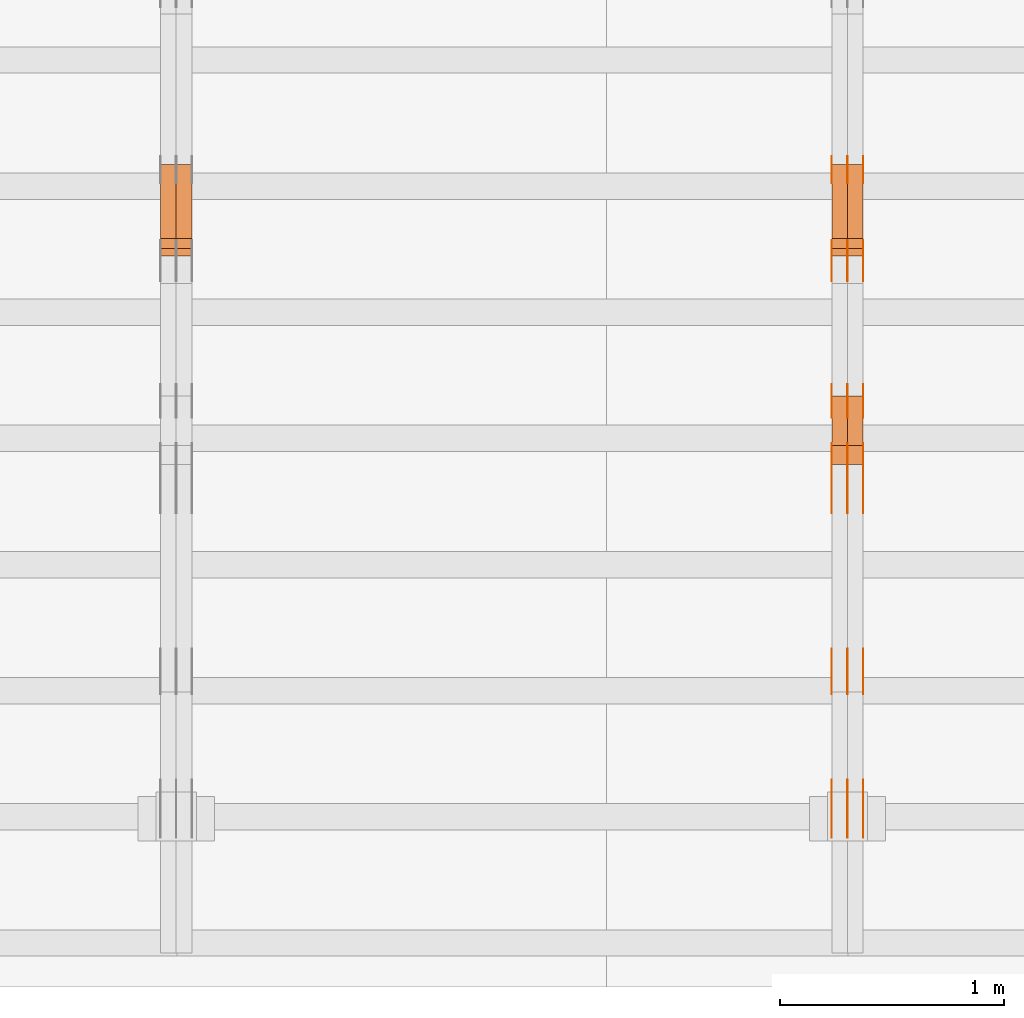
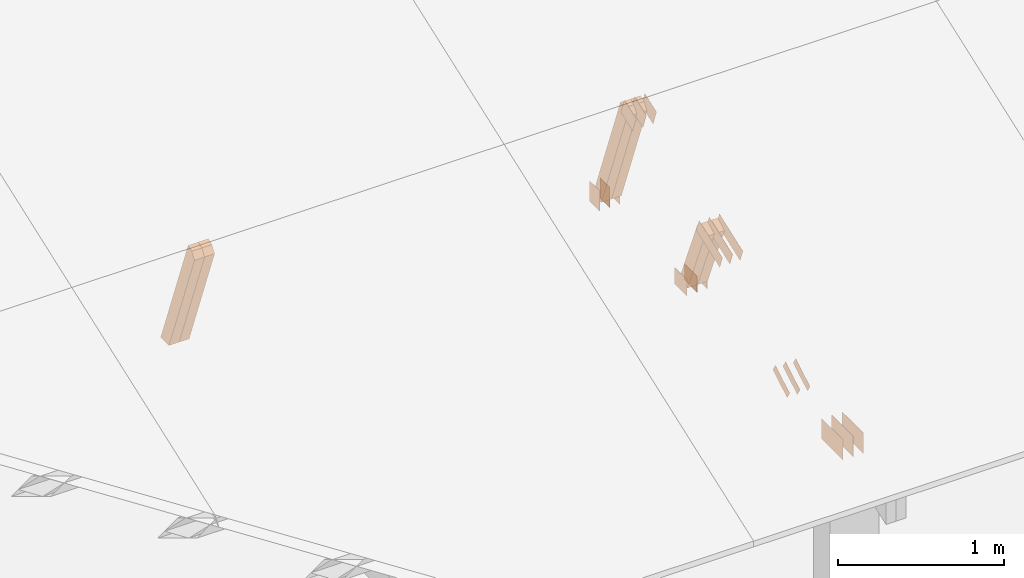
# One storey, part 73 of 189: 30 proxies.
"""IFC2X3 building model written with IfcOpenShell, lengths in millimetres."""

from ifc_helpers import new_model, entity, si_unit, converted_unit, derived_unit, direction, frame, frame_2d, origin, origin_2d_with_axis, place, context, subcontext, project, spatial, polyline, rectangle, outline, extrude, source, transform, mapped, material, type_object, type_shapes, element, save


model = new_model("IFC2X3")

# Units and contexts
model_context = context("Model", 3, precision=0.01, world=origin(), true_north=direction((6.12303176911189e-17, 1.0)))
body_context = subcontext(model_context, "Body", "Model", "MODEL_VIEW")
ifc_project = project(units=[si_unit("LENGTHUNIT", "METRE", prefix="MILLI"), si_unit("AREAUNIT", "SQUARE_METRE"), si_unit("VOLUMEUNIT", "CUBIC_METRE"), converted_unit("PLANEANGLEUNIT", "DEGREE", entity("IfcRatioMeasure", 0.0174532925199433), si_unit("PLANEANGLEUNIT", "RADIAN"), dimensions=[0, 0, 0, 0, 0, 0, 0]), si_unit("MASSUNIT", "GRAM", prefix="KILO"), derived_unit("MASSDENSITYUNIT", [(si_unit("MASSUNIT", "GRAM", prefix="KILO"), 1), (si_unit("LENGTHUNIT", "METRE"), -3)]), si_unit("TIMEUNIT", "SECOND"), si_unit("FREQUENCYUNIT", "HERTZ"), si_unit("THERMODYNAMICTEMPERATUREUNIT", "DEGREE_CELSIUS"), derived_unit("THERMALTRANSMITTANCEUNIT", [(si_unit("MASSUNIT", "GRAM", prefix="KILO"), 1), (si_unit("THERMODYNAMICTEMPERATUREUNIT", "KELVIN"), -1), (si_unit("TIMEUNIT", "SECOND"), -3)]), derived_unit("VOLUMETRICFLOWRATEUNIT", [(si_unit("LENGTHUNIT", "METRE"), 3), (si_unit("TIMEUNIT", "SECOND"), -1)]), si_unit("ELECTRICCURRENTUNIT", "AMPERE"), si_unit("ELECTRICVOLTAGEUNIT", "VOLT"), si_unit("POWERUNIT", "WATT"), si_unit("FORCEUNIT", "NEWTON"), si_unit("ILLUMINANCEUNIT", "LUX"), si_unit("LUMINOUSFLUXUNIT", "LUMEN"), si_unit("LUMINOUSINTENSITYUNIT", "CANDELA"), derived_unit("USERDEFINED", [(si_unit("MASSUNIT", "GRAM", prefix="KILO"), -1), (si_unit("LENGTHUNIT", "METRE"), -2), (si_unit("TIMEUNIT", "SECOND"), 3), (si_unit("LUMINOUSFLUXUNIT", "LUMEN"), 1)]), derived_unit("LINEARVELOCITYUNIT", [(si_unit("LENGTHUNIT", "METRE"), 1), (si_unit("TIMEUNIT", "SECOND"), -1)]), si_unit("PRESSUREUNIT", "PASCAL"), derived_unit("USERDEFINED", [(si_unit("LENGTHUNIT", "METRE"), -2), (si_unit("MASSUNIT", "GRAM", prefix="KILO"), 1), (si_unit("TIMEUNIT", "SECOND"), -2)])], contexts=[model_context])

# Site, building, storey
site_placement = place(None, origin())
site = spatial("IfcSite", under=ifc_project, at=site_placement, CompositionType="ELEMENT")
building_placement = place(site_placement, origin())
building = spatial("IfcBuilding", under=site, at=building_placement, CompositionType="ELEMENT")
storey_placement = place(building_placement, origin())
storey = spatial("IfcBuildingStorey", under=building, at=storey_placement, Name="Default", CompositionType="ELEMENT", Elevation=0.0)

# Proxies
ifc_material_1 = material(Name="IfcSurfaceStyle #73530")
building_element_proxy_type_1 = type_object("IfcBuildingElementProxyType", PredefinedType="NOTDEFINED", material=ifc_material_1)
shared_shape_1 = source(origin(), body_context, "Body", "SweptSolid", [
    extrude(rectangle(XDim=150.0, YDim=120.0, at=frame_2d((1.4210854715202e-14, -7.105427357601e-15), x_axis=(1.0, 0.0))), frame((75.0, 60.0004961323721, 0.0), z_axis=(0.0, 0.0, 1.0), x_axis=(-1.0, 0.0, 0.0)), (0.0, 0.0, 1.0), 1.3),
])
type_shapes(building_element_proxy_type_1, [shared_shape_1])
proxy_1_placement = place(building_placement, frame((12301.3, 2940.99169136763, 170.0), z_axis=(-1.0, 0.0, 0.0), x_axis=(0.0, 0.0, 1.0)))
element("IfcBuildingElementProxy", 1, at=proxy_1_placement, inside=storey, type_object=building_element_proxy_type_1, material=ifc_material_1, context=body_context, shape_type="MappedRepresentation", body=[
    mapped(shared_shape_1, transform((0.0, 0.0, 0.0), scale=1.0)),
])
ifc_material_2 = material(Name="IfcSurfaceStyle #73473")
building_element_proxy_type_2 = type_object("IfcBuildingElementProxyType", PredefinedType="NOTDEFINED", material=ifc_material_2)
shared_shape_2 = source(origin(), body_context, "Body", "SweptSolid", [
    extrude(rectangle(XDim=150.0, YDim=120.0, at=frame_2d((1.4210854715202e-14, -7.105427357601e-15), x_axis=(1.0, 0.0))), frame((75.0, 60.0004961323721, 0.0), z_axis=(0.0, 0.0, 1.0), x_axis=(-1.0, 0.0, 0.0)), (0.0, 0.0, 1.0), 1.29999999999999),
])
type_shapes(building_element_proxy_type_2, [shared_shape_2])
proxy_2_placement = place(building_placement, frame((12230.0, 2940.99169136763, 170.0), z_axis=(-1.0, 0.0, 0.0), x_axis=(0.0, 0.0, 1.0)))
element("IfcBuildingElementProxy", 2, at=proxy_2_placement, inside=storey, type_object=building_element_proxy_type_2, material=ifc_material_2, context=body_context, shape_type="MappedRepresentation", body=[
    mapped(shared_shape_2, transform((0.0, 0.0, 0.0), scale=1.0)),
])
ifc_material_3 = material(Name="IfcSurfaceStyle #73416")
building_element_proxy_type_3 = type_object("IfcBuildingElementProxyType", PredefinedType="NOTDEFINED", material=ifc_material_3)
shared_shape_3 = source(origin(), body_context, "Body", "SweptSolid", [
    extrude(rectangle(XDim=150.0, YDim=120.0, at=frame_2d((1.4210854715202e-14, -7.105427357601e-15), x_axis=(1.0, 0.0))), frame((75.0, 60.0004961323721, 0.0), z_axis=(0.0, 0.0, 1.0), x_axis=(-1.0, 0.0, 0.0)), (0.0, 0.0, 1.0), 1.29999999999999),
])
type_shapes(building_element_proxy_type_3, [shared_shape_3])
proxy_3_placement = place(building_placement, frame((12231.3, 2940.99169136763, 170.0), z_axis=(-1.0, 0.0, 0.0), x_axis=(0.0, 0.0, 1.0)))
element("IfcBuildingElementProxy", 3, at=proxy_3_placement, inside=storey, type_object=building_element_proxy_type_3, material=ifc_material_3, context=body_context, shape_type="MappedRepresentation", body=[
    mapped(shared_shape_3, transform((0.0, 0.0, 0.0), scale=1.0)),
])
ifc_material_4 = material(Name="IfcSurfaceStyle #73359")
building_element_proxy_type_4 = type_object("IfcBuildingElementProxyType", PredefinedType="NOTDEFINED", material=ifc_material_4)
shared_shape_4 = source(origin(), body_context, "Body", "SweptSolid", [
    extrude(rectangle(XDim=150.0, YDim=120.0, at=frame_2d((1.4210854715202e-14, -7.105427357601e-15), x_axis=(1.0, 0.0))), frame((75.0, 60.0004961323721, 0.0), z_axis=(0.0, 0.0, 1.0), x_axis=(-1.0, 0.0, 0.0)), (0.0, 0.0, 1.0), 1.29999999999999),
])
type_shapes(building_element_proxy_type_4, [shared_shape_4])
proxy_4_placement = place(building_placement, frame((12160.0, 2940.99169136763, 170.0), z_axis=(-1.0, 0.0, 0.0), x_axis=(0.0, 0.0, 1.0)))
element("IfcBuildingElementProxy", 4, at=proxy_4_placement, inside=storey, type_object=building_element_proxy_type_4, material=ifc_material_4, context=body_context, shape_type="MappedRepresentation", body=[
    mapped(shared_shape_4, transform((0.0, 0.0, 0.0), scale=1.0)),
])
ifc_material_5 = material(Name="IfcSurfaceStyle #73302")
building_element_proxy_type_5 = type_object("IfcBuildingElementProxyType", PredefinedType="NOTDEFINED", material=ifc_material_5)
shared_shape_5 = source(origin(), body_context, "Body", "SweptSolid", [
    extrude(outline(polyline([(-75.0008071857483, -59.9999039432187), (75.0002916555677, -59.9999039432187), (75.0008280609982, 59.9999039432187), (-75.0003125308176, 59.9999039432187), (-75.0008071857483, -59.9999039432187)])), frame((75.0008280609982, 60.0002349219685, 0.0), z_axis=(0.0, 0.0, 1.0), x_axis=(-1.0, 0.0, 0.0)), (0.0, 0.0, 1.0), 1.3),
])
type_shapes(building_element_proxy_type_5, [shared_shape_5])
proxy_5_placement = place(building_placement, frame((12301.3, 2502.466796875, 1113.95080566406), z_axis=(-1.0, 0.0, 0.0), x_axis=(0.0, 0.939692620785908, 0.342020143325669)))
element("IfcBuildingElementProxy", 5, at=proxy_5_placement, inside=storey, type_object=building_element_proxy_type_5, material=ifc_material_5, context=body_context, shape_type="MappedRepresentation", body=[
    mapped(shared_shape_5, transform((0.0, 0.0, 0.0), scale=1.0)),
])
ifc_material_6 = material(Name="IfcSurfaceStyle #73245")
building_element_proxy_type_6 = type_object("IfcBuildingElementProxyType", PredefinedType="NOTDEFINED", material=ifc_material_6)
shared_shape_6 = source(origin(), body_context, "Body", "SweptSolid", [
    extrude(outline(polyline([(-75.0008071857483, -59.9999039432187), (75.0002916555677, -59.9999039432187), (75.0008280609982, 59.9999039432187), (-75.0003125308176, 59.9999039432187), (-75.0008071857483, -59.9999039432187)])), frame((75.0008280609982, 60.0002349219685, 0.0), z_axis=(0.0, 0.0, 1.0), x_axis=(-1.0, 0.0, 0.0)), (0.0, 0.0, 1.0), 1.29999999999999),
])
type_shapes(building_element_proxy_type_6, [shared_shape_6])
proxy_6_placement = place(building_placement, frame((12230.0, 2502.466796875, 1113.95080566406), z_axis=(-1.0, 0.0, 0.0), x_axis=(0.0, 0.939692620785908, 0.342020143325669)))
element("IfcBuildingElementProxy", 6, at=proxy_6_placement, inside=storey, type_object=building_element_proxy_type_6, material=ifc_material_6, context=body_context, shape_type="MappedRepresentation", body=[
    mapped(shared_shape_6, transform((0.0, 0.0, 0.0), scale=1.0)),
])
ifc_material_7 = material(Name="IfcSurfaceStyle #73188")
building_element_proxy_type_7 = type_object("IfcBuildingElementProxyType", PredefinedType="NOTDEFINED", material=ifc_material_7)
shared_shape_7 = source(origin(), body_context, "Body", "SweptSolid", [
    extrude(outline(polyline([(-75.0008071857483, -59.9999039432187), (75.0002916555677, -59.9999039432187), (75.0008280609982, 59.9999039432187), (-75.0003125308176, 59.9999039432187), (-75.0008071857483, -59.9999039432187)])), frame((75.0008280609982, 60.0002349219685, 0.0), z_axis=(0.0, 0.0, 1.0), x_axis=(-1.0, 0.0, 0.0)), (0.0, 0.0, 1.0), 1.29999999999999),
])
type_shapes(building_element_proxy_type_7, [shared_shape_7])
proxy_7_placement = place(building_placement, frame((12231.3, 2502.466796875, 1113.95080566406), z_axis=(-1.0, 0.0, 0.0), x_axis=(0.0, 0.939692620785908, 0.342020143325669)))
element("IfcBuildingElementProxy", 7, at=proxy_7_placement, inside=storey, type_object=building_element_proxy_type_7, material=ifc_material_7, context=body_context, shape_type="MappedRepresentation", body=[
    mapped(shared_shape_7, transform((0.0, 0.0, 0.0), scale=1.0)),
])
ifc_material_8 = material(Name="IfcSurfaceStyle #73131")
building_element_proxy_type_8 = type_object("IfcBuildingElementProxyType", PredefinedType="NOTDEFINED", material=ifc_material_8)
shared_shape_8 = source(origin(), body_context, "Body", "SweptSolid", [
    extrude(outline(polyline([(-75.0008071857483, -59.9999039432187), (75.0002916555677, -59.9999039432187), (75.0008280609982, 59.9999039432187), (-75.0003125308176, 59.9999039432187), (-75.0008071857483, -59.9999039432187)])), frame((75.0008280609982, 60.0002349219685, 0.0), z_axis=(0.0, 0.0, 1.0), x_axis=(-1.0, 0.0, 0.0)), (0.0, 0.0, 1.0), 1.29999999999999),
])
type_shapes(building_element_proxy_type_8, [shared_shape_8])
proxy_8_placement = place(building_placement, frame((12160.0, 2502.466796875, 1113.95080566406), z_axis=(-1.0, 0.0, 0.0), x_axis=(0.0, 0.939692620785908, 0.342020143325669)))
element("IfcBuildingElementProxy", 8, at=proxy_8_placement, inside=storey, type_object=building_element_proxy_type_8, material=ifc_material_8, context=body_context, shape_type="MappedRepresentation", body=[
    mapped(shared_shape_8, transform((0.0, 0.0, 0.0), scale=1.0)),
])
ifc_material_9 = material(Name="IfcSurfaceStyle #72618")
building_element_proxy_type_9 = type_object("IfcBuildingElementProxyType", PredefinedType="NOTDEFINED", material=ifc_material_9)
shared_shape_9 = source(origin(), body_context, "Body", "SweptSolid", [
    extrude(rectangle(XDim=150.0, YDim=120.0, at=origin_2d_with_axis()), frame((75.0004757715869, 60.0, 0.0), z_axis=(0.0, 0.0, 1.0), x_axis=(-1.0, 0.0, 0.0)), (0.0, 0.0, 1.0), 1.3),
])
type_shapes(building_element_proxy_type_9, [shared_shape_9])
proxy_9_placement = place(building_placement, frame((12301.3, 1892.68702422841, 305.0), z_axis=(-1.0, 0.0, 0.0), x_axis=(0.0, 1.0, 0.0)))
element("IfcBuildingElementProxy", 9, at=proxy_9_placement, inside=storey, type_object=building_element_proxy_type_9, material=ifc_material_9, context=body_context, shape_type="MappedRepresentation", body=[
    mapped(shared_shape_9, transform((0.0, 0.0, 0.0), scale=1.0)),
])
ifc_material_10 = material(Name="IfcSurfaceStyle #72561")
building_element_proxy_type_10 = type_object("IfcBuildingElementProxyType", PredefinedType="NOTDEFINED", material=ifc_material_10)
shared_shape_10 = source(origin(), body_context, "Body", "SweptSolid", [
    extrude(rectangle(XDim=150.0, YDim=120.0, at=origin_2d_with_axis()), frame((75.0004757715869, 60.0, 0.0), z_axis=(0.0, 0.0, 1.0), x_axis=(-1.0, 0.0, 0.0)), (0.0, 0.0, 1.0), 1.29999999999999),
])
type_shapes(building_element_proxy_type_10, [shared_shape_10])
proxy_10_placement = place(building_placement, frame((12230.0, 1892.68702422841, 305.0), z_axis=(-1.0, 0.0, 0.0), x_axis=(0.0, 1.0, 0.0)))
element("IfcBuildingElementProxy", 10, at=proxy_10_placement, inside=storey, type_object=building_element_proxy_type_10, material=ifc_material_10, context=body_context, shape_type="MappedRepresentation", body=[
    mapped(shared_shape_10, transform((0.0, 0.0, 0.0), scale=1.0)),
])
ifc_material_11 = material(Name="IfcSurfaceStyle #72504")
building_element_proxy_type_11 = type_object("IfcBuildingElementProxyType", PredefinedType="NOTDEFINED", material=ifc_material_11)
shared_shape_11 = source(origin(), body_context, "Body", "SweptSolid", [
    extrude(rectangle(XDim=150.0, YDim=120.0, at=origin_2d_with_axis()), frame((75.0004757715869, 60.0, 0.0), z_axis=(0.0, 0.0, 1.0), x_axis=(-1.0, 0.0, 0.0)), (0.0, 0.0, 1.0), 1.29999999999999),
])
type_shapes(building_element_proxy_type_11, [shared_shape_11])
proxy_11_placement = place(building_placement, frame((12231.3, 1892.68702422841, 305.0), z_axis=(-1.0, 0.0, 0.0), x_axis=(0.0, 1.0, 0.0)))
element("IfcBuildingElementProxy", 11, at=proxy_11_placement, inside=storey, type_object=building_element_proxy_type_11, material=ifc_material_11, context=body_context, shape_type="MappedRepresentation", body=[
    mapped(shared_shape_11, transform((0.0, 0.0, 0.0), scale=1.0)),
])
ifc_material_12 = material(Name="IfcSurfaceStyle #72447")
building_element_proxy_type_12 = type_object("IfcBuildingElementProxyType", PredefinedType="NOTDEFINED", material=ifc_material_12)
shared_shape_12 = source(origin(), body_context, "Body", "SweptSolid", [
    extrude(rectangle(XDim=150.0, YDim=120.0, at=origin_2d_with_axis()), frame((75.0004757715869, 60.0, 0.0), z_axis=(0.0, 0.0, 1.0), x_axis=(-1.0, 0.0, 0.0)), (0.0, 0.0, 1.0), 1.29999999999999),
])
type_shapes(building_element_proxy_type_12, [shared_shape_12])
proxy_12_placement = place(building_placement, frame((12160.0, 1892.68702422841, 305.0), z_axis=(-1.0, 0.0, 0.0), x_axis=(0.0, 1.0, 0.0)))
element("IfcBuildingElementProxy", 12, at=proxy_12_placement, inside=storey, type_object=building_element_proxy_type_12, material=ifc_material_12, context=body_context, shape_type="MappedRepresentation", body=[
    mapped(shared_shape_12, transform((0.0, 0.0, 0.0), scale=1.0)),
])
ifc_material_13 = material(Name="IfcSurfaceStyle #72390")
building_element_proxy_type_13 = type_object("IfcBuildingElementProxyType", PredefinedType="NOTDEFINED", material=ifc_material_13)
shared_shape_13 = source(origin(), body_context, "Body", "SweptSolid", [
    extrude(outline(polyline([(-150.000217420008, -47.9999344162752), (150.000165800718, -47.9999344162752), (150.000227857633, 47.9999344162752), (-150.000176238343, 47.9999344162752), (-150.000217420008, -47.9999344162752)])), frame((150.000227857633, 48.0000430742566, 0.0), z_axis=(0.0, 0.0, 1.0), x_axis=(-1.0, 0.0, 0.0)), (0.0, 0.0, 1.0), 1.29999999999999),
])
type_shapes(building_element_proxy_type_13, [shared_shape_13])
proxy_13_placement = place(building_placement, frame((12301.3, 1464.46484375, 723.378723144533), z_axis=(-1.0, 0.0, 0.0), x_axis=(0.0, 0.939692620785908, 0.342020143325669)))
element("IfcBuildingElementProxy", 13, at=proxy_13_placement, inside=storey, type_object=building_element_proxy_type_13, material=ifc_material_13, context=body_context, shape_type="MappedRepresentation", body=[
    mapped(shared_shape_13, transform((0.0, 0.0, 0.0), scale=1.0)),
])
ifc_material_14 = material(Name="IfcSurfaceStyle #72333")
building_element_proxy_type_14 = type_object("IfcBuildingElementProxyType", PredefinedType="NOTDEFINED", material=ifc_material_14)
shared_shape_14 = source(origin(), body_context, "Body", "SweptSolid", [
    extrude(outline(polyline([(-150.000217420008, -47.9999344162752), (150.000165800718, -47.9999344162752), (150.000227857633, 47.9999344162752), (-150.000176238343, 47.9999344162752), (-150.000217420008, -47.9999344162752)])), frame((150.000227857633, 48.0000430742566, 0.0), z_axis=(0.0, 0.0, 1.0), x_axis=(-1.0, 0.0, 0.0)), (0.0, 0.0, 1.0), 1.29999999999998),
])
type_shapes(building_element_proxy_type_14, [shared_shape_14])
proxy_14_placement = place(building_placement, frame((12230.0, 1464.46484375, 723.378723144533), z_axis=(-1.0, 0.0, 0.0), x_axis=(0.0, 0.939692620785908, 0.342020143325669)))
element("IfcBuildingElementProxy", 14, at=proxy_14_placement, inside=storey, type_object=building_element_proxy_type_14, material=ifc_material_14, context=body_context, shape_type="MappedRepresentation", body=[
    mapped(shared_shape_14, transform((0.0, 0.0, 0.0), scale=1.0)),
])
ifc_material_15 = material(Name="IfcSurfaceStyle #72276")
building_element_proxy_type_15 = type_object("IfcBuildingElementProxyType", PredefinedType="NOTDEFINED", material=ifc_material_15)
shared_shape_15 = source(origin(), body_context, "Body", "SweptSolid", [
    extrude(outline(polyline([(-150.000217420008, -47.9999344162752), (150.000165800718, -47.9999344162752), (150.000227857633, 47.9999344162752), (-150.000176238343, 47.9999344162752), (-150.000217420008, -47.9999344162752)])), frame((150.000227857633, 48.0000430742566, 0.0), z_axis=(0.0, 0.0, 1.0), x_axis=(-1.0, 0.0, 0.0)), (0.0, 0.0, 1.0), 1.29999999999998),
])
type_shapes(building_element_proxy_type_15, [shared_shape_15])
proxy_15_placement = place(building_placement, frame((12231.3, 1464.46484375, 723.378723144533), z_axis=(-1.0, 0.0, 0.0), x_axis=(0.0, 0.939692620785908, 0.342020143325669)))
element("IfcBuildingElementProxy", 15, at=proxy_15_placement, inside=storey, type_object=building_element_proxy_type_15, material=ifc_material_15, context=body_context, shape_type="MappedRepresentation", body=[
    mapped(shared_shape_15, transform((0.0, 0.0, 0.0), scale=1.0)),
])
ifc_material_16 = material(Name="IfcSurfaceStyle #72219")
building_element_proxy_type_16 = type_object("IfcBuildingElementProxyType", PredefinedType="NOTDEFINED", material=ifc_material_16)
shared_shape_16 = source(origin(), body_context, "Body", "SweptSolid", [
    extrude(outline(polyline([(-150.000217420008, -47.9999344162752), (150.000165800718, -47.9999344162752), (150.000227857633, 47.9999344162752), (-150.000176238343, 47.9999344162752), (-150.000217420008, -47.9999344162752)])), frame((150.000227857633, 48.0000430742566, 0.0), z_axis=(0.0, 0.0, 1.0), x_axis=(-1.0, 0.0, 0.0)), (0.0, 0.0, 1.0), 1.29999999999998),
])
type_shapes(building_element_proxy_type_16, [shared_shape_16])
proxy_16_placement = place(building_placement, frame((12160.0, 1464.46484375, 723.378723144533), z_axis=(-1.0, 0.0, 0.0), x_axis=(0.0, 0.939692620785908, 0.342020143325669)))
element("IfcBuildingElementProxy", 16, at=proxy_16_placement, inside=storey, type_object=building_element_proxy_type_16, material=ifc_material_16, context=body_context, shape_type="MappedRepresentation", body=[
    mapped(shared_shape_16, transform((0.0, 0.0, 0.0), scale=1.0)),
])
ifc_material_17 = material(Name="IfcSurfaceStyle #71706")
building_element_proxy_type_17 = type_object("IfcBuildingElementProxyType", PredefinedType="NOTDEFINED", material=ifc_material_17)
shared_shape_17 = source(origin(), body_context, "Body", "SweptSolid", [
    extrude(outline(polyline([(-100.000388510424, -29.9995882393532), (100.000691805256, -29.9995882393532), (100.000392424258, 29.9995882393532), (-100.00069571909, 29.9995882393532), (-100.000388510424, -29.9995882393532)])), frame((100.000691805256, 30.0002299338894, 0.0), z_axis=(0.0, 0.0, 1.0), x_axis=(-1.0, 0.0, 0.0)), (0.0, 0.0, 1.0), 1.3),
])
type_shapes(building_element_proxy_type_17, [shared_shape_17])
proxy_17_placement = place(building_placement, frame((12301.3, 656.945055513712, 219.45219322107), z_axis=(-1.0, 0.0, 0.0), x_axis=(0.0, 0.858392121304013, 0.51299411895576)))
element("IfcBuildingElementProxy", 17, at=proxy_17_placement, inside=storey, type_object=building_element_proxy_type_17, material=ifc_material_17, context=body_context, shape_type="MappedRepresentation", body=[
    mapped(shared_shape_17, transform((0.0, 0.0, 0.0), scale=1.0)),
])
ifc_material_18 = material(Name="IfcSurfaceStyle #71649")
building_element_proxy_type_18 = type_object("IfcBuildingElementProxyType", PredefinedType="NOTDEFINED", material=ifc_material_18)
shared_shape_18 = source(origin(), body_context, "Body", "SweptSolid", [
    extrude(outline(polyline([(-100.000388510424, -29.9995882393532), (100.000691805256, -29.9995882393532), (100.000392424258, 29.9995882393532), (-100.00069571909, 29.9995882393532), (-100.000388510424, -29.9995882393532)])), frame((100.000691805256, 30.0002299338894, 0.0), z_axis=(0.0, 0.0, 1.0), x_axis=(-1.0, 0.0, 0.0)), (0.0, 0.0, 1.0), 1.29999999999998),
])
type_shapes(building_element_proxy_type_18, [shared_shape_18])
proxy_18_placement = place(building_placement, frame((12230.0, 656.945055513712, 219.45219322107), z_axis=(-1.0, 0.0, 0.0), x_axis=(0.0, 0.858392121304013, 0.51299411895576)))
element("IfcBuildingElementProxy", 18, at=proxy_18_placement, inside=storey, type_object=building_element_proxy_type_18, material=ifc_material_18, context=body_context, shape_type="MappedRepresentation", body=[
    mapped(shared_shape_18, transform((0.0, 0.0, 0.0), scale=1.0)),
])
ifc_material_19 = material(Name="IfcSurfaceStyle #71592")
building_element_proxy_type_19 = type_object("IfcBuildingElementProxyType", PredefinedType="NOTDEFINED", material=ifc_material_19)
shared_shape_19 = source(origin(), body_context, "Body", "SweptSolid", [
    extrude(outline(polyline([(-100.000388510424, -29.9995882393532), (100.000691805256, -29.9995882393532), (100.000392424258, 29.9995882393532), (-100.00069571909, 29.9995882393532), (-100.000388510424, -29.9995882393532)])), frame((100.000691805256, 30.0002299338894, 0.0), z_axis=(0.0, 0.0, 1.0), x_axis=(-1.0, 0.0, 0.0)), (0.0, 0.0, 1.0), 1.29999999999998),
])
type_shapes(building_element_proxy_type_19, [shared_shape_19])
proxy_19_placement = place(building_placement, frame((12231.3, 656.945055513712, 219.45219322107), z_axis=(-1.0, 0.0, 0.0), x_axis=(0.0, 0.858392121304013, 0.51299411895576)))
element("IfcBuildingElementProxy", 19, at=proxy_19_placement, inside=storey, type_object=building_element_proxy_type_19, material=ifc_material_19, context=body_context, shape_type="MappedRepresentation", body=[
    mapped(shared_shape_19, transform((0.0, 0.0, 0.0), scale=1.0)),
])
ifc_material_20 = material(Name="IfcSurfaceStyle #71535")
building_element_proxy_type_20 = type_object("IfcBuildingElementProxyType", PredefinedType="NOTDEFINED", material=ifc_material_20)
shared_shape_20 = source(origin(), body_context, "Body", "SweptSolid", [
    extrude(outline(polyline([(-100.000388510424, -29.9995882393532), (100.000691805256, -29.9995882393532), (100.000392424258, 29.9995882393532), (-100.00069571909, 29.9995882393532), (-100.000388510424, -29.9995882393532)])), frame((100.000691805256, 30.0002299338894, 0.0), z_axis=(0.0, 0.0, 1.0), x_axis=(-1.0, 0.0, 0.0)), (0.0, 0.0, 1.0), 1.29999999999999),
])
type_shapes(building_element_proxy_type_20, [shared_shape_20])
proxy_20_placement = place(building_placement, frame((12160.0, 656.945055513712, 219.45219322107), z_axis=(-1.0, 0.0, 0.0), x_axis=(0.0, 0.858392121304013, 0.51299411895576)))
element("IfcBuildingElementProxy", 20, at=proxy_20_placement, inside=storey, type_object=building_element_proxy_type_20, material=ifc_material_20, context=body_context, shape_type="MappedRepresentation", body=[
    mapped(shared_shape_20, transform((0.0, 0.0, 0.0), scale=1.0)),
])
ifc_material_21 = material(Name="IfcSurfaceStyle #70170")
building_element_proxy_type_21 = type_object("IfcBuildingElementProxyType", PredefinedType="NOTDEFINED", material=ifc_material_21)
shared_shape_21 = source(origin(), body_context, "Body", "SweptSolid", [
    extrude(rectangle(XDim=258.0, YDim=151.999992370605, at=origin_2d_with_axis()), frame((129.0, 76.0000049445079, 0.0), z_axis=(0.0, 0.0, 1.0), x_axis=(-1.0, 0.0, 0.0)), (0.0, 0.0, 1.0), 0.999999999999984),
])
type_shapes(building_element_proxy_type_21, [shared_shape_21])
proxy_21_placement = place(building_placement, frame((12301.0, 16.236328125, 268.138222870533), z_axis=(-1.0, 0.0, 0.0), x_axis=(0.0, 1.0, 0.0)))
element("IfcBuildingElementProxy", 21, at=proxy_21_placement, inside=storey, type_object=building_element_proxy_type_21, material=ifc_material_21, Name="GNT100S 152x258", context=body_context, shape_type="MappedRepresentation", body=[
    mapped(shared_shape_21, transform((0.0, 0.0, 0.0), scale=1.0)),
])
ifc_material_22 = material(Name="IfcSurfaceStyle #70113")
building_element_proxy_type_22 = type_object("IfcBuildingElementProxyType", PredefinedType="NOTDEFINED", material=ifc_material_22)
shared_shape_22 = source(origin(), body_context, "Body", "SweptSolid", [
    extrude(rectangle(XDim=258.0, YDim=151.999992370605, at=origin_2d_with_axis()), frame((129.0, 76.0000049445079, 0.0), z_axis=(0.0, 0.0, 1.0), x_axis=(-1.0, 0.0, 0.0)), (0.0, 0.0, 1.0), 0.999999999999984),
])
type_shapes(building_element_proxy_type_22, [shared_shape_22])
proxy_22_placement = place(building_placement, frame((12230.0, 16.236328125, 268.138222870533), z_axis=(-1.0, 0.0, 0.0), x_axis=(0.0, 1.0, 0.0)))
element("IfcBuildingElementProxy", 22, at=proxy_22_placement, inside=storey, type_object=building_element_proxy_type_22, material=ifc_material_22, Name="GNT100S 152x258", context=body_context, shape_type="MappedRepresentation", body=[
    mapped(shared_shape_22, transform((0.0, 0.0, 0.0), scale=1.0)),
])
ifc_material_23 = material(Name="IfcSurfaceStyle #70056")
building_element_proxy_type_23 = type_object("IfcBuildingElementProxyType", PredefinedType="NOTDEFINED", material=ifc_material_23)
shared_shape_23 = source(origin(), body_context, "Body", "SweptSolid", [
    extrude(rectangle(XDim=258.0, YDim=151.999992370605, at=origin_2d_with_axis()), frame((129.0, 76.0000049445079, 0.0), z_axis=(0.0, 0.0, 1.0), x_axis=(-1.0, 0.0, 0.0)), (0.0, 0.0, 1.0), 0.999999999999984),
])
type_shapes(building_element_proxy_type_23, [shared_shape_23])
proxy_23_placement = place(building_placement, frame((12231.0, 16.236328125, 268.138222870533), z_axis=(-1.0, 0.0, 0.0), x_axis=(0.0, 1.0, 0.0)))
element("IfcBuildingElementProxy", 23, at=proxy_23_placement, inside=storey, type_object=building_element_proxy_type_23, material=ifc_material_23, Name="GNT100S 152x258", context=body_context, shape_type="MappedRepresentation", body=[
    mapped(shared_shape_23, transform((0.0, 0.0, 0.0), scale=1.0)),
])
ifc_material_24 = material(Name="IfcSurfaceStyle #69999")
building_element_proxy_type_24 = type_object("IfcBuildingElementProxyType", PredefinedType="NOTDEFINED", material=ifc_material_24)
shared_shape_24 = source(origin(), body_context, "Body", "SweptSolid", [
    extrude(rectangle(XDim=258.0, YDim=151.999992370605, at=origin_2d_with_axis()), frame((129.0, 76.0000049445079, 0.0), z_axis=(0.0, 0.0, 1.0), x_axis=(-1.0, 0.0, 0.0)), (0.0, 0.0, 1.0), 0.999999999999984),
])
type_shapes(building_element_proxy_type_24, [shared_shape_24])
proxy_24_placement = place(building_placement, frame((12160.0, 16.236328125, 268.138222870533), z_axis=(-1.0, 0.0, 0.0), x_axis=(0.0, 1.0, 0.0)))
element("IfcBuildingElementProxy", 24, at=proxy_24_placement, inside=storey, type_object=building_element_proxy_type_24, material=ifc_material_24, Name="GNT100S 152x258", context=body_context, shape_type="MappedRepresentation", body=[
    mapped(shared_shape_24, transform((0.0, 0.0, 0.0), scale=1.0)),
])
ifc_material_25 = material(Name="IfcSurfaceStyle #65730")
building_element_proxy_type_25 = type_object("IfcBuildingElementProxyType", Name="T1-W14 65728", PredefinedType="NOTDEFINED", material=ifc_material_25)
shared_shape_25 = source(origin(), body_context, "Body", "SweptSolid", [
    extrude(outline(polyline([(-526.068269984593, -47.5004595774917), (341.27769108205, -47.5004595774917), (373.679499344758, 0.000392511719837607), (373.092506900368, 47.5002633216318), (-561.981427342584, 47.5002633216318), (-526.068269984593, -47.5004595774917)])), frame((373.67978783425, 47.5005221796964, 0.0), z_axis=(0.0, 0.0, 1.0), x_axis=(-1.0, 0.0, 0.0)), (0.0, 0.0, 1.0), 69.9999999999999),
])
type_shapes(building_element_proxy_type_25, [shared_shape_25])
proxy_25_placement = place(building_placement, frame((12300.0, 2693.38241954499, 1120.21215048788), z_axis=(-1.0, 0.0, 0.0), x_axis=(0.0, 0.353606472447916, -0.935394281916958)))
element("IfcBuildingElementProxy", 25, at=proxy_25_placement, inside=storey, type_object=building_element_proxy_type_25, material=ifc_material_25, Name="T1-W14", context=body_context, shape_type="MappedRepresentation", body=[
    mapped(shared_shape_25, transform((0.0, 0.0, 0.0), scale=1.0)),
])
ifc_material_26 = material(Name="IfcSurfaceStyle #65664")
building_element_proxy_type_26 = type_object("IfcBuildingElementProxyType", Name="T1-W14 65662", PredefinedType="NOTDEFINED", material=ifc_material_26)
shared_shape_26 = source(origin(), body_context, "Body", "SweptSolid", [
    extrude(outline(polyline([(-526.068269984593, -47.5004595774917), (341.27769108205, -47.5004595774917), (373.679499344758, 0.000392511719837607), (373.092506900368, 47.5002633216318), (-561.981427342584, 47.5002633216318), (-526.068269984593, -47.5004595774917)])), frame((373.67978783425, 47.5005221796964, 0.0), z_axis=(0.0, 0.0, 1.0), x_axis=(-1.0, 0.0, 0.0)), (0.0, 0.0, 1.0), 69.9999999999999),
])
type_shapes(building_element_proxy_type_26, [shared_shape_26])
proxy_26_placement = place(building_placement, frame((12230.0, 2693.38241954499, 1120.21215048788), z_axis=(-1.0, 0.0, 0.0), x_axis=(0.0, 0.353606472447916, -0.935394281916958)))
element("IfcBuildingElementProxy", 26, at=proxy_26_placement, inside=storey, type_object=building_element_proxy_type_26, material=ifc_material_26, Name="T1-W14", context=body_context, shape_type="MappedRepresentation", body=[
    mapped(shared_shape_26, transform((0.0, 0.0, 0.0), scale=1.0)),
])
ifc_material_27 = material(Name="IfcSurfaceStyle #65202")
building_element_proxy_type_27 = type_object("IfcBuildingElementProxyType", Name="T1-W15 65200", PredefinedType="NOTDEFINED", material=ifc_material_27)
shared_shape_27 = source(origin(), body_context, "Body", "SweptSolid", [
    extrude(outline(polyline([(-317.132720418368, -47.5005147440206), (220.445242566881, -47.5005147440206), (227.5021778825, -0.000126286009697951), (225.500088907744, 47.5005778870255), (-356.314788938758, 47.5005778870255), (-317.132720418368, -47.5005147440206)])), frame((227.5021778825, 47.5005778870255, 0.0), z_axis=(0.0, 0.0, 1.0), x_axis=(-1.0, 0.0, 0.0)), (0.0, 0.0, 1.0), 70.0),
])
type_shapes(building_element_proxy_type_27, [shared_shape_27])
proxy_27_placement = place(building_placement, frame((12300.0, 1767.47882447529, 784.714556181707), z_axis=(-1.0, 0.0, 0.0), x_axis=(0.0, 0.381283266795389, -0.924458257825542)))
element("IfcBuildingElementProxy", 27, at=proxy_27_placement, inside=storey, type_object=building_element_proxy_type_27, material=ifc_material_27, Name="T1-W15", context=body_context, shape_type="MappedRepresentation", body=[
    mapped(shared_shape_27, transform((0.0, 0.0, 0.0), scale=1.0)),
])
ifc_material_28 = material(Name="IfcSurfaceStyle #65136")
building_element_proxy_type_28 = type_object("IfcBuildingElementProxyType", Name="T1-W15 65134", PredefinedType="NOTDEFINED", material=ifc_material_28)
shared_shape_28 = source(origin(), body_context, "Body", "SweptSolid", [
    extrude(outline(polyline([(-317.132720418368, -47.5005147440206), (220.445242566881, -47.5005147440206), (227.5021778825, -0.000126286009697951), (225.500088907744, 47.5005778870255), (-356.314788938758, 47.5005778870255), (-317.132720418368, -47.5005147440206)])), frame((227.5021778825, 47.5005778870255, 0.0), z_axis=(0.0, 0.0, 1.0), x_axis=(-1.0, 0.0, 0.0)), (0.0, 0.0, 1.0), 70.0),
])
type_shapes(building_element_proxy_type_28, [shared_shape_28])
proxy_28_placement = place(building_placement, frame((12230.0, 1767.47882447529, 784.714556181707), z_axis=(-1.0, 0.0, 0.0), x_axis=(0.0, 0.381283266795389, -0.924458257825542)))
element("IfcBuildingElementProxy", 28, at=proxy_28_placement, inside=storey, type_object=building_element_proxy_type_28, material=ifc_material_28, Name="T1-W15", context=body_context, shape_type="MappedRepresentation", body=[
    mapped(shared_shape_28, transform((0.0, 0.0, 0.0), scale=1.0)),
])
ifc_material_29 = material(Name="IfcSurfaceStyle #49940")
building_element_proxy_type_29 = type_object("IfcBuildingElementProxyType", Name="T1-W14 49938", PredefinedType="NOTDEFINED", material=ifc_material_29)
shared_shape_29 = source(origin(), body_context, "Body", "SweptSolid", [
    extrude(outline(polyline([(-526.068269984593, -47.5004595774917), (341.27769108205, -47.5004595774917), (373.679499344758, 0.000392511719837607), (373.092506900368, 47.5002633216318), (-561.981427342584, 47.5002633216318), (-526.068269984593, -47.5004595774917)])), frame((373.67978783425, 47.5005221796964, 0.0), z_axis=(0.0, 0.0, 1.0), x_axis=(-1.0, 0.0, 0.0)), (0.0, 0.0, 1.0), 69.9999999999999),
])
type_shapes(building_element_proxy_type_29, [shared_shape_29])
proxy_29_placement = place(building_placement, frame((9300.0, 2693.38241954499, 1120.21215048788), z_axis=(-1.0, 0.0, 0.0), x_axis=(0.0, 0.353606472447916, -0.935394281916958)))
element("IfcBuildingElementProxy", 29, at=proxy_29_placement, inside=storey, type_object=building_element_proxy_type_29, material=ifc_material_29, Name="T1-W14", context=body_context, shape_type="MappedRepresentation", body=[
    mapped(shared_shape_29, transform((0.0, 0.0, 0.0), scale=1.0)),
])
ifc_material_30 = material(Name="IfcSurfaceStyle #49874")
building_element_proxy_type_30 = type_object("IfcBuildingElementProxyType", Name="T1-W14 49872", PredefinedType="NOTDEFINED", material=ifc_material_30)
shared_shape_30 = source(origin(), body_context, "Body", "SweptSolid", [
    extrude(outline(polyline([(-526.068269984593, -47.5004595774917), (341.27769108205, -47.5004595774917), (373.679499344758, 0.000392511719837607), (373.092506900368, 47.5002633216318), (-561.981427342584, 47.5002633216318), (-526.068269984593, -47.5004595774917)])), frame((373.67978783425, 47.5005221796964, 0.0), z_axis=(0.0, 0.0, 1.0), x_axis=(-1.0, 0.0, 0.0)), (0.0, 0.0, 1.0), 69.9999999999999),
])
type_shapes(building_element_proxy_type_30, [shared_shape_30])
proxy_30_placement = place(building_placement, frame((9230.0, 2693.38241954499, 1120.21215048788), z_axis=(-1.0, 0.0, 0.0), x_axis=(0.0, 0.353606472447916, -0.935394281916958)))
element("IfcBuildingElementProxy", 30, at=proxy_30_placement, inside=storey, type_object=building_element_proxy_type_30, material=ifc_material_30, Name="T1-W14", context=body_context, shape_type="MappedRepresentation", body=[
    mapped(shared_shape_30, transform((0.0, 0.0, 0.0), scale=1.0)),
])

save(model, "model.ifc")
